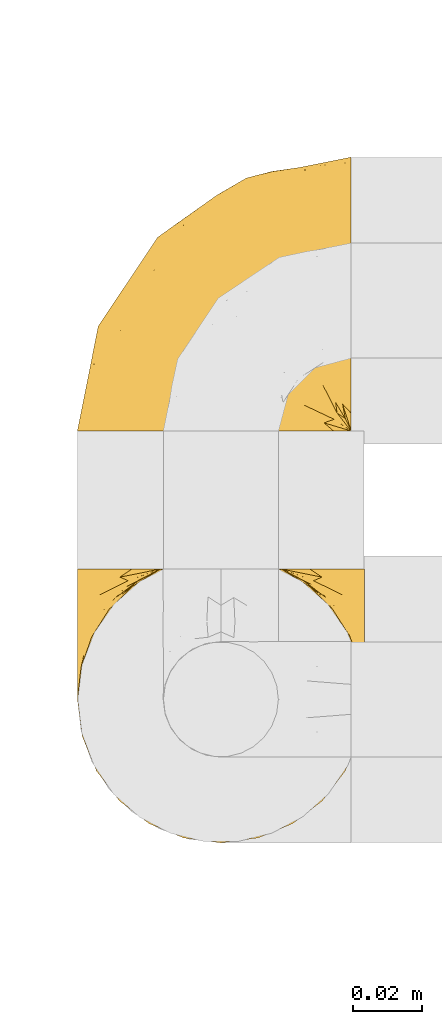
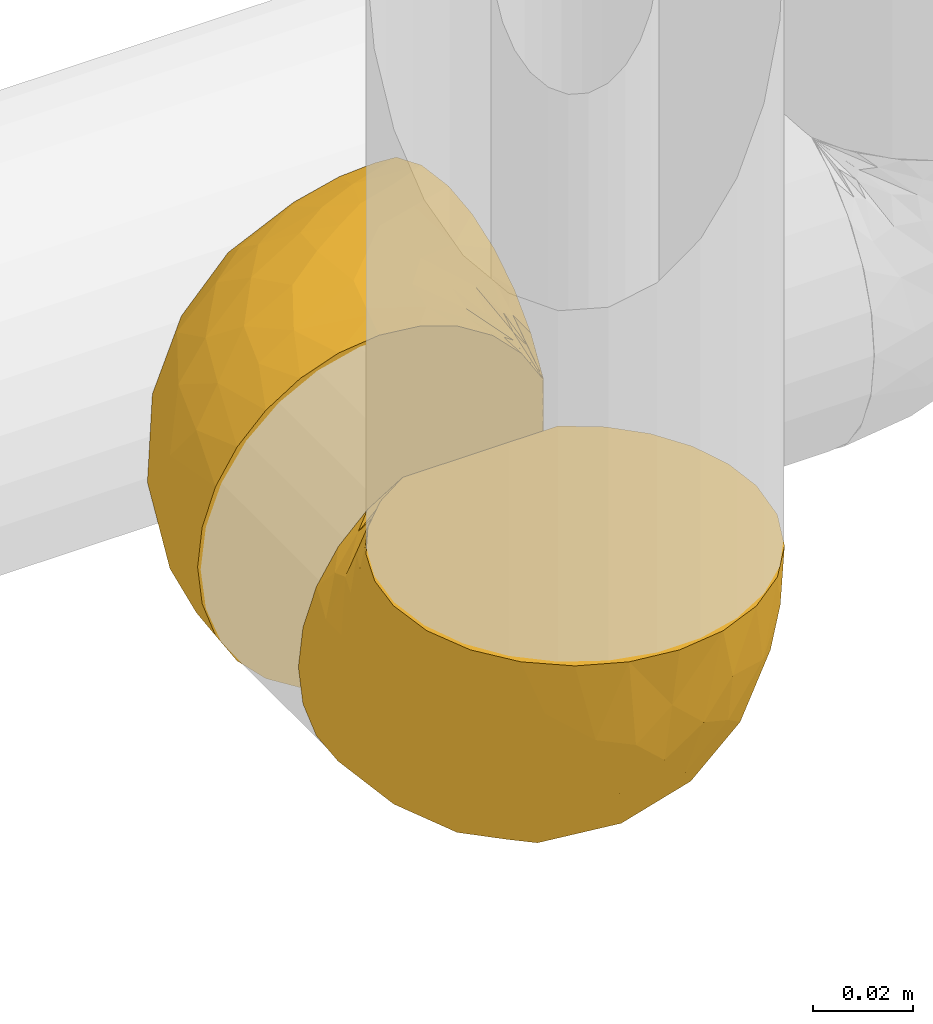
# One storey, part 445 of 827: 2 coverings.
"""IFC2X3 building model written with IfcOpenShell, lengths in millimetres."""

from ifc_helpers import new_model, entity, si_unit, converted_unit, derived_unit, direction, frame, origin, place, context, subcontext, project, spatial, faceted_brep, element, save


model = new_model("IFC2X3")

# Units and contexts
model_context = context("Model", 3, precision=0.01, world=origin(), true_north=direction((6.12303176911189e-17, 1.0)))
body_context = subcontext(model_context, "Body", "Model", "MODEL_VIEW")
ifc_project = project(units=[si_unit("LENGTHUNIT", "METRE", prefix="MILLI"), si_unit("AREAUNIT", "SQUARE_METRE"), si_unit("VOLUMEUNIT", "CUBIC_METRE"), converted_unit("PLANEANGLEUNIT", "DEGREE", entity("IfcRatioMeasure", 0.0174532925199433), si_unit("PLANEANGLEUNIT", "RADIAN"), dimensions=[0, 0, 0, 0, 0, 0, 0]), si_unit("MASSUNIT", "GRAM", prefix="KILO"), derived_unit("MASSDENSITYUNIT", [(si_unit("MASSUNIT", "GRAM", prefix="KILO"), 1), (si_unit("LENGTHUNIT", "METRE"), -3)]), derived_unit("MOMENTOFINERTIAUNIT", [(si_unit("LENGTHUNIT", "METRE"), 4)]), si_unit("TIMEUNIT", "SECOND"), si_unit("FREQUENCYUNIT", "HERTZ"), si_unit("THERMODYNAMICTEMPERATUREUNIT", "DEGREE_CELSIUS"), derived_unit("THERMALTRANSMITTANCEUNIT", [(si_unit("MASSUNIT", "GRAM", prefix="KILO"), 1), (si_unit("THERMODYNAMICTEMPERATUREUNIT", "KELVIN"), -1), (si_unit("TIMEUNIT", "SECOND"), -3)]), derived_unit("VOLUMETRICFLOWRATEUNIT", [(si_unit("LENGTHUNIT", "METRE"), 3), (si_unit("TIMEUNIT", "SECOND"), -1)]), derived_unit("MASSFLOWRATEUNIT", [(si_unit("MASSUNIT", "GRAM", prefix="KILO"), 1), (si_unit("TIMEUNIT", "SECOND"), -1)]), derived_unit("ROTATIONALFREQUENCYUNIT", [(si_unit("TIMEUNIT", "SECOND"), -1)]), si_unit("ELECTRICCURRENTUNIT", "AMPERE"), si_unit("ELECTRICVOLTAGEUNIT", "VOLT"), si_unit("POWERUNIT", "WATT"), si_unit("FORCEUNIT", "NEWTON", prefix="KILO"), si_unit("ILLUMINANCEUNIT", "LUX"), si_unit("LUMINOUSFLUXUNIT", "LUMEN"), si_unit("LUMINOUSINTENSITYUNIT", "CANDELA"), derived_unit("USERDEFINED", [(si_unit("MASSUNIT", "GRAM", prefix="KILO"), -1), (si_unit("LENGTHUNIT", "METRE"), -2), (si_unit("TIMEUNIT", "SECOND"), 3), (si_unit("LUMINOUSFLUXUNIT", "LUMEN"), 1)]), derived_unit("LINEARVELOCITYUNIT", [(si_unit("LENGTHUNIT", "METRE"), 1), (si_unit("TIMEUNIT", "SECOND"), -1)]), si_unit("PRESSUREUNIT", "PASCAL"), derived_unit("USERDEFINED", [(si_unit("LENGTHUNIT", "METRE"), -2), (si_unit("MASSUNIT", "GRAM", prefix="KILO"), 1), (si_unit("TIMEUNIT", "SECOND"), -2)]), derived_unit("LINEARFORCEUNIT", [(si_unit("MASSUNIT", "GRAM", prefix="KILO"), 1), (si_unit("LENGTHUNIT", "METRE"), 1), (si_unit("TIMEUNIT", "SECOND"), -2), (si_unit("LENGTHUNIT", "METRE"), -1)]), derived_unit("PLANARFORCEUNIT", [(si_unit("MASSUNIT", "GRAM", prefix="KILO"), 1), (si_unit("LENGTHUNIT", "METRE"), 1), (si_unit("TIMEUNIT", "SECOND"), -2), (si_unit("LENGTHUNIT", "METRE"), -2)])], contexts=[model_context])

# Site, building, storey
site_placement = place(None, origin())
site = spatial("IfcSite", under=ifc_project, at=site_placement, CompositionType="ELEMENT")
building_placement = place(site_placement, origin())
building = spatial("IfcBuilding", under=site, at=building_placement, CompositionType="ELEMENT")
storey_placement = place(building_placement, frame((0.0, 0.0, 28200.0)))
storey = spatial("IfcBuildingStorey", under=building, at=storey_placement, Name="08", CompositionType="ELEMENT", Elevation=28200.0)

# Coverings
covering_1_placement = place(storey_placement, frame((58830.44, 15400.76, 1657.08)))
element("IfcCovering", 1, at=covering_1_placement, inside=storey, Name=":ADSK_", ObjectType=":ADSK_", PredefinedType="INSULATION", context=body_context, shape_type="Brep", body=[
    faceted_brep([(81.15, 81.45, 25.28), (76.16, 81.45, 17.35), (69.53, 81.45, 10.72), (61.6, 81.45, 5.74), (52.75, 81.45, 2.64), (43.45, 81.45, 1.6), (34.13, 81.45, 2.65), (25.28, 81.45, 5.74), (17.35, 81.45, 10.73), (10.72, 81.45, 17.36), (5.74, 81.45, 25.29), (2.64, 81.45, 34.14), (1.6, 81.45, 43.45), (2.66, 81.45, 52.82), (5.79, 81.45, 61.71), (10.83, 81.45, 69.67), (17.53, 81.45, 76.31), (25.53, 81.45, 81.27), (26.45, 81.45, 81.27), (27.37, 81.45, 81.27), (28.17, 81.45, 81.27), (29.49, 81.45, 81.27), (30.81, 81.45, 81.27), (32.13, 81.45, 81.27), (33.45, 81.45, 81.27), (34.78, 81.45, 81.27), (36.1, 81.45, 81.27), (37.42, 81.45, 81.27), (38.74, 81.45, 81.27), (40.06, 81.45, 81.27), (41.38, 81.45, 81.27), (42.7, 81.45, 81.27), (44.02, 81.45, 81.27), (45.34, 81.45, 81.27), (46.66, 81.45, 81.27), (47.58, 81.45, 81.27), (48.5, 81.45, 81.27), (49.41, 81.45, 81.27), (50.33, 81.45, 81.27), (51.25, 81.45, 81.27), (52.17, 81.45, 81.27), (53.09, 81.45, 81.27), (54.01, 81.45, 81.27), (54.93, 81.45, 81.27), (55.85, 81.45, 81.27), (56.76, 81.45, 81.27), (57.68, 81.45, 81.27), (58.6, 81.45, 81.27), (59.52, 81.45, 81.27), (60.44, 81.45, 81.27), (61.36, 81.45, 81.27), (69.37, 81.45, 76.3), (76.07, 81.45, 69.66), (81.11, 81.45, 61.69), (84.24, 81.45, 52.8), (85.3, 81.45, 43.45), (84.24, 81.45, 34.13), (17.52, 76.3, 81.45), (10.83, 69.67, 81.45), (5.79, 61.7, 81.45), (2.66, 52.81, 81.45), (1.6, 43.45, 81.45), (3.02, 32.61, 81.45), (7.2, 22.52, 81.45), (13.85, 13.85, 81.45), (22.52, 7.2, 81.45), (32.61, 3.02, 81.45), (43.45, 1.6, 81.45), (54.28, 3.02, 81.45), (64.37, 7.2, 81.45), (73.04, 13.85, 81.45), (79.69, 22.52, 81.45), (83.87, 32.61, 81.45), (85.3, 43.45, 81.45), (84.23, 52.81, 81.45), (81.1, 61.7, 81.45), (76.06, 69.67, 81.45), (69.37, 76.3, 81.45), (61.36, 81.27, 81.45), (60.44, 81.27, 81.45), (59.12, 81.27, 81.45), (58.0, 81.27, 81.45), (56.88, 81.27, 81.45), (55.76, 81.27, 81.45), (54.64, 81.27, 81.45), (53.52, 81.27, 81.45), (52.4, 81.27, 81.45), (51.28, 81.27, 81.45), (50.16, 81.27, 81.45), (49.04, 81.27, 81.45), (47.92, 81.27, 81.45), (46.8, 81.27, 81.45), (45.68, 81.27, 81.45), (44.56, 81.27, 81.45), (43.45, 81.27, 81.45), (42.12, 81.27, 81.45), (40.8, 81.27, 81.45), (39.48, 81.27, 81.45), (38.16, 81.27, 81.45), (36.84, 81.27, 81.45), (35.52, 81.27, 81.45), (34.2, 81.27, 81.45), (32.88, 81.27, 81.45), (31.96, 81.27, 81.45), (31.05, 81.27, 81.45), (30.13, 81.27, 81.45), (29.21, 81.27, 81.45), (28.29, 81.27, 81.45), (27.37, 81.27, 81.45), (26.45, 81.27, 81.45), (25.53, 81.27, 81.45), (54.08, 81.31, 81.33), (55.16, 81.33, 81.32), (36.18, 81.31, 81.33), (35.13, 81.32, 81.32), (44.01, 81.31, 81.33), (45.08, 81.32, 81.32), (61.36, 81.32, 81.32), (59.98, 81.32, 81.32), (46.18, 81.32, 81.32), (26.74, 81.32, 81.32), (47.36, 81.32, 81.32), (29.67, 81.32, 81.32), (28.72, 81.3, 81.34), (39.77, 81.32, 81.32), (52.96, 81.33, 81.31), (51.84, 81.31, 81.33), (40.8, 81.33, 81.31), (41.87, 81.32, 81.32), (42.94, 81.32, 81.33), (27.77, 81.32, 81.32), (48.4, 81.31, 81.33), (37.21, 81.32, 81.32), (33.54, 81.31, 81.33), (32.49, 81.32, 81.32), (30.69, 81.32, 81.32), (50.69, 81.32, 81.32), (49.6, 81.33, 81.31), (56.32, 81.32, 81.32), (57.44, 81.31, 81.33), (58.88, 81.33, 81.31), (25.53, 81.32, 81.32), (61.36, 81.36, 81.3), (61.36, 81.4, 81.29), (25.53, 81.4, 81.29), (25.53, 81.36, 81.3), (61.36, 81.29, 81.4), (61.36, 81.3, 81.36), (25.53, 81.3, 81.36), (25.53, 81.29, 81.4), (31.59, 81.35, 81.3), (38.71, 81.31, 81.33), (3.97, 58.5, 74.06), (1.6, 71.95, 45.99), (3.97, 74.57, 58.35), (8.09, 73.93, 67.76), (8.09, 78.18, 66.18), (16.43, 78.04, 76.46), (15.73, 76.23, 77.33), (1.6, 45.99, 71.95), (10.79, 74.01, 72.25), (13.99, 73.57, 78.91), (8.08, 66.66, 76.42), (14.0, 79.09, 73.52), (12.83, 73.14, 76.9), (3.18, 60.34, 65.25), (1.6, 48.54, 62.45), (1.6, 45.36, 74.31), (3.28, 67.22, 59.38), (1.6, 62.45, 48.54), (6.28, 68.67, 67.72), (1.6, 55.49, 55.49), (19.06, 77.84, 79.73), (8.08, 68.16, 73.23), (1.6, 74.31, 45.36), (32.11, 38.78, 15.81), (29.62, 62.1, 6.4), (43.45, 50.89, 7.67), (2.45, 36.91, 68.46), (2.5, 40.37, 59.33), (9.73, 27.86, 48.7), (17.97, 15.77, 53.94), (10.24, 20.13, 65.02), (4.78, 31.54, 60.77), (4.78, 28.25, 72.07), (8.01, 57.26, 26.25), (8.01, 69.99, 22.29), (13.85, 64.58, 16.0), (2.42, 50.64, 46.93), (21.17, 51.97, 14.19), (35.73, 5.72, 58.46), (27.43, 7.42, 61.51), (43.45, 66.14, 4.64), (17.97, 11.35, 68.93), (35.71, 21.64, 29.62), (29.47, 28.57, 24.85), (3.41, 55.38, 38.55), (3.94, 68.51, 31.27), (21.17, 67.48, 9.35), (7.92, 40.78, 37.15), (4.25, 41.53, 47.07), (11.75, 46.11, 26.49), (18.31, 40.32, 23.01), (24.94, 38.36, 19.4), (28.78, 11.84, 48.06), (35.82, 12.56, 42.46), (43.45, 7.67, 50.89), (28.38, 19.39, 35.78), (43.45, 24.98, 24.98), (43.45, 37.94, 16.33), (43.45, 4.64, 66.14), (21.21, 28.09, 30.96), (16.48, 23.73, 41.83), (13.85, 34.03, 33.28), (43.45, 16.33, 37.94), (82.11, 29.29, 67.39), (51.41, 5.77, 58.47), (57.45, 21.44, 32.5), (54.78, 38.8, 15.79), (73.03, 64.58, 15.99), (65.7, 67.49, 9.34), (76.65, 22.9, 56.91), (68.92, 12.54, 63.5), (68.01, 20.04, 44.08), (78.88, 57.26, 26.24), (78.88, 69.99, 22.27), (82.94, 68.51, 31.26), (64.44, 34.54, 23.95), (84.49, 38.81, 63.79), (85.3, 48.54, 62.45), (85.3, 45.99, 71.95), (85.3, 74.31, 45.36), (57.84, 5.36, 67.83), (76.65, 18.96, 70.28), (51.19, 12.79, 42.11), (57.26, 62.11, 6.39), (78.14, 33.14, 43.54), (82.35, 33.44, 58.03), (65.7, 51.98, 14.18), (84.61, 43.42, 56.34), (84.36, 48.62, 48.09), (85.3, 62.45, 48.54), (85.3, 55.49, 55.49), (73.03, 49.68, 21.78), (83.48, 55.37, 38.54), (85.3, 71.95, 45.99), (84.54, 36.37, 72.79), (73.03, 34.04, 33.26), (79.54, 44.1, 35.53), (59.46, 9.99, 53.66), (73.5, 26.41, 43.03), (82.57, 39.19, 49.68), (82.92, 58.5, 74.06), (83.62, 67.22, 59.37), (82.92, 74.57, 58.34), (78.81, 73.92, 67.75), (72.9, 73.57, 78.91), (74.06, 73.14, 76.9), (78.81, 66.19, 78.08), (78.81, 68.16, 73.23), (67.83, 77.84, 79.73), (71.15, 76.23, 77.34), (72.91, 79.08, 73.51), (70.47, 78.04, 76.45), (78.81, 77.18, 66.41), (80.62, 68.66, 67.7), (76.11, 74.0, 72.24), (83.71, 60.34, 65.25)], [[[0, 1, 2, 3, 4, 5, 6, 7, 8, 9, 10, 11, 12, 13, 14, 15, 16, 17, 18, 19, 20, 21, 22, 23, 24, 25, 26, 27, 28, 29, 30, 31, 32, 33, 34, 35, 36, 37, 38, 39, 40, 41, 42, 43, 44, 45, 46, 47, 48, 49, 50, 51, 52, 53, 54, 55, 56]], [[57, 58, 59, 60, 61, 62, 63, 64, 65, 66, 67, 68, 69, 70, 71, 72, 73, 74, 75, 76, 77, 78, 79, 80, 81, 82, 83, 84, 85, 86, 87, 88, 89, 90, 91, 92, 93, 94, 95, 96, 97, 98, 99, 100, 101, 102, 103, 104, 105, 106, 107, 108, 109, 110]], [[111, 84, 112]], [[113, 26, 114]], [[114, 101, 100]], [[115, 93, 116]], [[79, 117, 118]], [[33, 116, 119]], [[117, 49, 118]], [[19, 18, 120]], [[119, 121, 34]], [[122, 21, 123]], [[97, 96, 124]], [[86, 125, 126]], [[116, 92, 119]], [[127, 96, 128]], [[32, 129, 115]], [[19, 120, 130]], [[121, 90, 131]], [[94, 115, 129]], [[115, 116, 32]], [[118, 49, 48]], [[113, 99, 132]], [[133, 114, 25]], [[24, 134, 133]], [[135, 22, 122]], [[136, 137, 88]], [[84, 83, 112]], [[138, 82, 139]], [[130, 20, 19]], [[118, 48, 140]], [[81, 140, 139]], [[123, 21, 20]], [[141, 120, 18]], [[139, 82, 81]], [[130, 107, 123]], [[49, 117, 142, 143, 50]], [[18, 17, 144, 145, 141]], [[79, 78, 146, 147, 117]], [[109, 141, 148, 149, 110]], [[102, 133, 134]], [[105, 135, 122]], [[118, 80, 79]], [[80, 118, 140]], [[120, 109, 108]], [[47, 46, 140, 48]], [[81, 80, 140]], [[44, 112, 138]], [[93, 115, 94]], [[46, 139, 140]], [[46, 45, 139]], [[139, 45, 138]], [[138, 112, 83]], [[85, 84, 111]], [[112, 43, 111]], [[83, 82, 138]], [[106, 122, 123]], [[105, 122, 106]], [[21, 122, 22]], [[124, 29, 28]], [[33, 32, 116]], [[128, 129, 31]], [[32, 31, 129]], [[34, 33, 119]], [[116, 93, 92]], [[129, 95, 94]], [[95, 129, 128]], [[41, 40, 125, 42]], [[119, 91, 121]], [[36, 35, 131, 37]], [[137, 131, 89]], [[121, 131, 35]], [[90, 121, 91]], [[119, 92, 91]], [[136, 126, 39]], [[125, 86, 85]], [[42, 125, 111]], [[85, 111, 125]], [[150, 23, 22]], [[130, 108, 107]], [[130, 123, 20]], [[107, 106, 123]], [[137, 37, 131]], [[136, 38, 137]], [[89, 88, 137]], [[131, 90, 89]], [[124, 151, 97]], [[40, 39, 126]], [[87, 126, 136]], [[86, 126, 87]], [[136, 88, 87]], [[40, 126, 125]], [[39, 38, 136]], [[95, 128, 96]], [[30, 128, 31]], [[29, 124, 127]], [[127, 128, 30]], [[151, 124, 28]], [[127, 30, 29]], [[127, 124, 96]], [[151, 98, 97]], [[45, 44, 138]], [[26, 113, 132]], [[113, 100, 99]], [[132, 151, 27]], [[27, 26, 132]], [[26, 25, 114]], [[100, 113, 114]], [[101, 133, 102]], [[133, 101, 114]], [[28, 27, 151]], [[132, 99, 98]], [[23, 134, 24]], [[25, 24, 133]], [[134, 23, 150]], [[135, 104, 150]], [[150, 104, 103]], [[103, 102, 134]], [[130, 120, 108]], [[109, 120, 141]], [[42, 111, 43]], [[112, 44, 43]], [[104, 135, 105]], [[134, 150, 103]], [[135, 150, 22]], [[35, 34, 121]], [[137, 38, 37]], [[98, 151, 132]], [[59, 152, 60]], [[13, 153, 154]], [[155, 156, 154]], [[157, 158, 141]], [[159, 60, 152]], [[160, 157, 155]], [[161, 162, 58]], [[58, 162, 59]], [[144, 16, 163]], [[58, 57, 161]], [[162, 161, 164]], [[157, 163, 155]], [[163, 16, 15]], [[57, 149, 161]], [[152, 165, 166]], [[157, 144, 163]], [[60, 159, 167, 61]], [[156, 14, 154]], [[163, 156, 155]], [[155, 154, 168]], [[168, 154, 169]], [[155, 170, 160]], [[57, 110, 149]], [[144, 17, 16]], [[156, 15, 14]], [[171, 165, 168]], [[158, 164, 172]], [[14, 13, 154]], [[157, 141, 145, 144]], [[173, 164, 158]], [[173, 160, 170]], [[171, 166, 165]], [[168, 165, 170]], [[168, 169, 171]], [[152, 173, 165]], [[170, 155, 168]], [[165, 173, 170]], [[160, 173, 158]], [[172, 149, 148]], [[148, 141, 158]], [[158, 157, 160]], [[152, 166, 159]], [[173, 152, 162]], [[59, 162, 152]], [[13, 12, 174, 153]], [[153, 169, 154]], [[15, 156, 163]], [[162, 164, 173]], [[172, 164, 161]], [[149, 172, 161]], [[158, 172, 148]], [[175, 176, 177]], [[178, 166, 179]], [[180, 181, 182]], [[183, 184, 178]], [[185, 186, 187]], [[171, 188, 179]], [[174, 12, 11]], [[189, 176, 175]], [[190, 66, 191]], [[176, 6, 192]], [[193, 65, 64]], [[63, 184, 182]], [[63, 182, 64]], [[65, 193, 191]], [[184, 63, 62]], [[175, 194, 195]], [[196, 169, 197]], [[174, 11, 197]], [[8, 7, 198]], [[187, 9, 8]], [[197, 169, 153, 174]], [[197, 11, 10]], [[186, 197, 10]], [[199, 180, 200]], [[197, 185, 196]], [[201, 189, 202]], [[201, 187, 189]], [[195, 203, 175]], [[191, 204, 190]], [[176, 7, 6]], [[177, 176, 192]], [[189, 198, 176]], [[65, 191, 66]], [[198, 187, 8]], [[205, 206, 190]], [[9, 186, 10]], [[181, 207, 204]], [[208, 175, 177, 209]], [[66, 190, 210]], [[211, 212, 213]], [[190, 204, 205]], [[180, 182, 183]], [[193, 182, 181]], [[62, 61, 167]], [[196, 185, 199]], [[196, 200, 188]], [[6, 5, 192]], [[176, 198, 7]], [[187, 198, 189]], [[187, 186, 9]], [[197, 186, 185]], [[200, 180, 183]], [[180, 213, 212]], [[179, 183, 178]], [[185, 201, 199]], [[210, 190, 206]], [[210, 67, 66]], [[205, 204, 207]], [[194, 205, 207]], [[194, 214, 205]], [[195, 194, 207]], [[208, 194, 175]], [[207, 211, 195]], [[202, 203, 211]], [[212, 207, 181]], [[202, 211, 213]], [[201, 202, 213]], [[189, 175, 203]], [[199, 201, 213]], [[187, 201, 185]], [[180, 199, 213]], [[196, 199, 200]], [[211, 203, 195]], [[189, 203, 202]], [[207, 212, 211]], [[180, 212, 181]], [[214, 194, 208]], [[214, 206, 205]], [[196, 188, 169]], [[181, 204, 191]], [[182, 193, 64]], [[191, 193, 181]], [[178, 62, 167]], [[182, 184, 183]], [[62, 178, 184]], [[178, 167, 159, 166]], [[171, 179, 166]], [[200, 183, 179]], [[179, 188, 200]], [[169, 188, 171]], [[71, 215, 72]], [[206, 216, 210]], [[217, 208, 218]], [[216, 68, 210]], [[219, 220, 2]], [[221, 222, 223]], [[224, 225, 226]], [[227, 223, 217]], [[228, 229, 230]], [[56, 231, 226]], [[232, 222, 69]], [[56, 55, 231]], [[70, 233, 71]], [[71, 233, 215]], [[0, 56, 226]], [[208, 217, 234]], [[218, 177, 235]], [[221, 236, 237]], [[238, 220, 219]], [[1, 219, 2]], [[68, 216, 232]], [[235, 3, 220]], [[235, 192, 4]], [[1, 0, 225]], [[228, 239, 229]], [[240, 241, 242]], [[243, 238, 219]], [[224, 226, 244]], [[226, 241, 244]], [[3, 235, 4]], [[69, 222, 70]], [[225, 219, 1]], [[218, 235, 238]], [[243, 219, 224]], [[218, 227, 217]], [[3, 2, 220]], [[218, 208, 209, 177]], [[226, 231, 245, 241]], [[215, 228, 246]], [[247, 248, 236]], [[248, 224, 244]], [[223, 222, 249]], [[233, 222, 221]], [[242, 239, 240]], [[248, 247, 243]], [[217, 223, 249]], [[250, 247, 236]], [[216, 234, 249]], [[218, 238, 227]], [[192, 235, 177]], [[192, 5, 4]], [[72, 246, 73]], [[235, 220, 238]], [[226, 225, 0]], [[219, 225, 224]], [[240, 248, 244]], [[239, 242, 229]], [[236, 248, 251]], [[68, 67, 210]], [[234, 216, 206]], [[216, 249, 232]], [[234, 206, 214, 208]], [[249, 234, 217]], [[222, 232, 249]], [[69, 68, 232]], [[246, 228, 230]], [[237, 228, 215]], [[243, 227, 238]], [[223, 227, 247]], [[73, 246, 230]], [[215, 246, 72]], [[248, 243, 224]], [[227, 243, 247]], [[237, 236, 251]], [[250, 221, 223]], [[222, 233, 70]], [[215, 233, 221]], [[221, 237, 215]], [[239, 237, 251]], [[237, 239, 228]], [[239, 251, 240]], [[248, 240, 251]], [[241, 240, 244]], [[221, 250, 236]], [[223, 247, 250]], [[74, 230, 252]], [[253, 254, 255]], [[146, 77, 256]], [[257, 258, 259]], [[260, 256, 257]], [[260, 261, 147]], [[75, 74, 252]], [[51, 143, 262]], [[263, 143, 142, 117]], [[256, 77, 76]], [[252, 258, 75]], [[253, 241, 254]], [[254, 245, 54]], [[258, 256, 76]], [[53, 52, 264]], [[255, 265, 253]], [[254, 264, 255]], [[255, 264, 262]], [[75, 258, 76]], [[265, 255, 266]], [[255, 262, 263]], [[51, 50, 143]], [[54, 245, 231, 55]], [[51, 262, 52]], [[253, 267, 242]], [[254, 54, 53]], [[266, 259, 265]], [[146, 78, 77]], [[263, 117, 261]], [[146, 256, 260]], [[257, 259, 261]], [[267, 253, 265]], [[229, 267, 252]], [[242, 267, 229]], [[242, 241, 253]], [[252, 267, 259]], [[255, 263, 266]], [[259, 267, 265]], [[261, 117, 147]], [[263, 261, 266]], [[259, 266, 261]], [[230, 74, 73]], [[230, 229, 252]], [[259, 258, 252]], [[254, 241, 245]], [[53, 264, 254]], [[52, 262, 264]], [[143, 263, 262]], [[258, 257, 256]], [[261, 260, 257]], [[146, 260, 147]]]),
])
covering_2_placement = place(storey_placement, frame((58830.44, 15520.87, 1657.08)))
element("IfcCovering", 2, at=covering_2_placement, inside=storey, Name=":ADSK_", ObjectType=":ADSK_", PredefinedType="INSULATION", context=body_context, shape_type="Brep", body=[
    faceted_brep([(25.28, 1.6, 81.15), (17.35, 1.6, 76.16), (10.72, 1.6, 69.53), (5.74, 1.6, 61.6), (2.64, 1.6, 52.75), (1.6, 1.6, 43.45), (2.65, 1.6, 34.13), (5.74, 1.6, 25.28), (10.73, 1.6, 17.35), (17.36, 1.6, 10.72), (25.29, 1.6, 5.74), (34.14, 1.6, 2.64), (43.45, 1.6, 1.6), (52.82, 1.6, 2.66), (61.71, 1.6, 5.79), (69.67, 1.6, 10.83), (76.31, 1.6, 17.53), (81.27, 1.6, 25.53), (81.27, 1.6, 26.45), (81.27, 1.6, 27.37), (81.27, 1.6, 28.17), (81.27, 1.6, 29.49), (81.27, 1.6, 30.81), (81.27, 1.6, 32.13), (81.27, 1.6, 33.45), (81.27, 1.6, 34.78), (81.27, 1.6, 36.1), (81.27, 1.6, 37.42), (81.27, 1.6, 38.74), (81.27, 1.6, 40.06), (81.27, 1.6, 41.38), (81.27, 1.6, 42.7), (81.27, 1.6, 44.02), (81.27, 1.6, 45.34), (81.27, 1.6, 46.66), (81.27, 1.6, 47.58), (81.27, 1.6, 48.5), (81.27, 1.6, 49.41), (81.27, 1.6, 50.33), (81.27, 1.6, 51.25), (81.27, 1.6, 52.17), (81.27, 1.6, 53.09), (81.27, 1.6, 54.01), (81.27, 1.6, 54.93), (81.27, 1.6, 55.85), (81.27, 1.6, 56.76), (81.27, 1.6, 57.68), (81.27, 1.6, 58.6), (81.27, 1.6, 59.52), (81.27, 1.6, 60.44), (81.27, 1.6, 61.36), (76.3, 1.6, 69.37), (69.66, 1.6, 76.07), (61.69, 1.6, 81.11), (52.8, 1.6, 84.24), (43.45, 1.6, 85.3), (34.13, 1.6, 84.24), (81.45, 6.74, 17.52), (81.45, 13.37, 10.83), (81.45, 21.34, 5.79), (81.45, 30.23, 2.66), (81.45, 39.6, 1.6), (81.45, 50.43, 3.02), (81.45, 60.52, 7.2), (81.45, 69.19, 13.85), (81.45, 75.84, 22.52), (81.45, 80.02, 32.61), (81.45, 81.45, 43.45), (81.45, 80.02, 54.28), (81.45, 75.84, 64.37), (81.45, 69.19, 73.04), (81.45, 60.52, 79.69), (81.45, 50.43, 83.87), (81.45, 39.6, 85.3), (81.45, 30.23, 84.23), (81.45, 21.34, 81.1), (81.45, 13.37, 76.06), (81.45, 6.74, 69.37), (81.45, 1.77, 61.36), (81.45, 1.77, 60.44), (81.45, 1.77, 59.12), (81.45, 1.77, 58.0), (81.45, 1.77, 56.88), (81.45, 1.77, 55.76), (81.45, 1.77, 54.64), (81.45, 1.77, 53.52), (81.45, 1.77, 52.4), (81.45, 1.77, 51.28), (81.45, 1.77, 50.16), (81.45, 1.77, 49.04), (81.45, 1.77, 47.92), (81.45, 1.77, 46.8), (81.45, 1.77, 45.68), (81.45, 1.77, 44.56), (81.45, 1.77, 43.45), (81.45, 1.77, 42.12), (81.45, 1.77, 40.8), (81.45, 1.77, 39.48), (81.45, 1.77, 38.16), (81.45, 1.77, 36.84), (81.45, 1.77, 35.52), (81.45, 1.77, 34.2), (81.45, 1.77, 32.88), (81.45, 1.77, 31.96), (81.45, 1.77, 31.05), (81.45, 1.77, 30.13), (81.45, 1.77, 29.21), (81.45, 1.77, 28.29), (81.45, 1.77, 27.37), (81.45, 1.77, 26.45), (81.45, 1.77, 25.53), (81.33, 1.73, 54.08), (81.32, 1.72, 55.16), (81.33, 1.73, 36.18), (81.32, 1.72, 35.13), (81.33, 1.73, 44.01), (81.32, 1.73, 45.08), (81.32, 1.72, 61.36), (81.32, 1.72, 59.98), (81.32, 1.72, 46.18), (81.32, 1.72, 26.74), (81.32, 1.72, 47.36), (81.32, 1.73, 29.67), (81.34, 1.74, 28.72), (81.32, 1.72, 39.77), (81.31, 1.71, 52.96), (81.33, 1.73, 51.84), (81.31, 1.71, 40.8), (81.32, 1.72, 41.87), (81.33, 1.73, 42.94), (81.32, 1.72, 27.77), (81.33, 1.73, 48.4), (81.32, 1.72, 37.21), (81.33, 1.73, 33.54), (81.32, 1.72, 32.49), (81.32, 1.72, 30.69), (81.32, 1.72, 50.69), (81.31, 1.71, 49.6), (81.32, 1.72, 56.32), (81.33, 1.73, 57.44), (81.31, 1.71, 58.88), (81.32, 1.72, 25.53), (81.3, 1.68, 61.36), (81.29, 1.64, 61.36), (81.29, 1.64, 25.53), (81.3, 1.68, 25.53), (81.4, 1.75, 61.36), (81.36, 1.74, 61.36), (81.36, 1.74, 25.53), (81.4, 1.75, 25.53), (81.3, 1.7, 31.59), (81.33, 1.73, 38.71), (74.06, 24.54, 3.97), (45.99, 11.1, 1.6), (58.35, 8.47, 3.97), (67.76, 9.11, 8.09), (66.18, 4.86, 8.09), (76.46, 5.0, 16.43), (77.33, 6.81, 15.73), (71.95, 37.05, 1.6), (72.25, 9.03, 10.79), (78.91, 9.47, 13.99), (76.42, 16.39, 8.08), (73.52, 3.95, 14.0), (76.9, 9.9, 12.83), (65.25, 22.7, 3.18), (62.45, 34.5, 1.6), (74.31, 37.68, 1.6), (59.38, 15.82, 3.28), (48.54, 20.6, 1.6), (67.72, 14.37, 6.28), (55.49, 27.55, 1.6), (79.73, 5.2, 19.06), (73.23, 14.88, 8.08), (45.36, 8.73, 1.6), (15.81, 44.27, 32.11), (6.4, 20.94, 29.62), (7.67, 32.15, 43.45), (68.46, 46.13, 2.45), (59.33, 42.67, 2.5), (48.7, 55.18, 9.73), (53.94, 67.27, 17.97), (65.02, 62.91, 10.24), (60.77, 51.5, 4.78), (72.07, 54.79, 4.78), (26.25, 25.78, 8.01), (22.29, 13.05, 8.01), (16.0, 18.46, 13.85), (46.93, 32.4, 2.42), (14.19, 31.07, 21.17), (58.46, 77.32, 35.73), (61.51, 75.62, 27.43), (4.64, 16.9, 43.45), (68.93, 71.69, 17.97), (29.62, 61.4, 35.71), (24.85, 54.47, 29.47), (38.55, 27.66, 3.41), (31.27, 14.53, 3.94), (9.35, 15.56, 21.17), (37.15, 42.26, 7.92), (47.07, 41.51, 4.25), (26.49, 36.93, 11.75), (23.01, 42.72, 18.31), (19.4, 44.68, 24.94), (48.06, 71.2, 28.78), (42.46, 70.48, 35.82), (50.89, 75.37, 43.45), (35.78, 63.65, 28.38), (24.98, 58.06, 43.45), (16.33, 45.11, 43.45), (66.14, 78.4, 43.45), (30.96, 54.95, 21.21), (41.83, 59.31, 16.48), (33.28, 49.01, 13.85), (37.94, 66.71, 43.45), (67.39, 53.75, 82.11), (58.47, 77.27, 51.41), (32.5, 61.6, 57.45), (15.79, 44.24, 54.78), (15.99, 18.46, 73.03), (9.34, 15.55, 65.7), (56.91, 60.14, 76.65), (63.5, 70.5, 68.92), (44.08, 63.0, 68.01), (26.24, 25.78, 78.88), (22.27, 13.05, 78.88), (31.26, 14.53, 82.94), (23.95, 48.5, 64.44), (63.79, 44.23, 84.49), (62.45, 34.5, 85.3), (71.95, 37.05, 85.3), (45.36, 8.73, 85.3), (67.83, 77.68, 57.84), (70.28, 64.08, 76.65), (42.11, 70.25, 51.19), (6.39, 20.93, 57.26), (43.54, 49.9, 78.14), (58.03, 49.6, 82.35), (14.18, 31.06, 65.7), (56.34, 39.62, 84.61), (48.09, 34.42, 84.36), (48.54, 20.6, 85.3), (55.49, 27.55, 85.3), (21.78, 33.36, 73.03), (38.54, 27.68, 83.48), (45.99, 11.1, 85.3), (72.79, 46.67, 84.54), (33.26, 49.0, 73.03), (35.53, 38.94, 79.54), (53.66, 73.05, 59.46), (43.03, 56.63, 73.5), (49.68, 43.85, 82.57), (74.06, 24.54, 82.92), (59.37, 15.82, 83.62), (58.34, 8.47, 82.92), (67.75, 9.12, 78.81), (78.91, 9.47, 72.9), (76.9, 9.91, 74.06), (78.08, 16.85, 78.81), (73.23, 14.88, 78.81), (79.73, 5.2, 67.83), (77.34, 6.81, 71.15), (73.51, 3.96, 72.91), (76.45, 5.0, 70.47), (66.41, 5.86, 78.81), (67.7, 14.38, 80.62), (72.24, 9.04, 76.11), (65.25, 22.7, 83.71)], [[[0, 1, 2, 3, 4, 5, 6, 7, 8, 9, 10, 11, 12, 13, 14, 15, 16, 17, 18, 19, 20, 21, 22, 23, 24, 25, 26, 27, 28, 29, 30, 31, 32, 33, 34, 35, 36, 37, 38, 39, 40, 41, 42, 43, 44, 45, 46, 47, 48, 49, 50, 51, 52, 53, 54, 55, 56]], [[57, 58, 59, 60, 61, 62, 63, 64, 65, 66, 67, 68, 69, 70, 71, 72, 73, 74, 75, 76, 77, 78, 79, 80, 81, 82, 83, 84, 85, 86, 87, 88, 89, 90, 91, 92, 93, 94, 95, 96, 97, 98, 99, 100, 101, 102, 103, 104, 105, 106, 107, 108, 109, 110]], [[111, 84, 112]], [[113, 26, 114]], [[114, 101, 100]], [[115, 93, 116]], [[79, 117, 118]], [[33, 116, 119]], [[117, 49, 118]], [[19, 18, 120]], [[119, 121, 34]], [[122, 21, 123]], [[97, 96, 124]], [[86, 125, 126]], [[116, 92, 119]], [[127, 96, 128]], [[32, 129, 115]], [[19, 120, 130]], [[121, 90, 131]], [[94, 115, 129]], [[115, 116, 32]], [[118, 49, 48]], [[113, 99, 132]], [[133, 114, 25]], [[24, 134, 133]], [[135, 22, 122]], [[136, 137, 88]], [[84, 83, 112]], [[138, 82, 139]], [[130, 20, 19]], [[118, 48, 140]], [[81, 140, 139]], [[123, 21, 20]], [[141, 120, 18]], [[139, 82, 81]], [[130, 107, 123]], [[49, 117, 142, 143, 50]], [[18, 17, 144, 145, 141]], [[79, 78, 146, 147, 117]], [[109, 141, 148, 149, 110]], [[102, 133, 134]], [[105, 135, 122]], [[118, 80, 79]], [[80, 118, 140]], [[120, 109, 108]], [[47, 46, 140, 48]], [[81, 80, 140]], [[44, 112, 138]], [[93, 115, 94]], [[46, 139, 140]], [[46, 45, 139]], [[139, 45, 138]], [[138, 112, 83]], [[85, 84, 111]], [[112, 43, 111]], [[83, 82, 138]], [[106, 122, 123]], [[105, 122, 106]], [[21, 122, 22]], [[124, 29, 28]], [[33, 32, 116]], [[128, 129, 31]], [[32, 31, 129]], [[34, 33, 119]], [[116, 93, 92]], [[129, 95, 94]], [[95, 129, 128]], [[41, 40, 125, 42]], [[119, 91, 121]], [[36, 35, 131, 37]], [[137, 131, 89]], [[121, 131, 35]], [[90, 121, 91]], [[119, 92, 91]], [[136, 126, 39]], [[125, 86, 85]], [[42, 125, 111]], [[85, 111, 125]], [[150, 23, 22]], [[130, 108, 107]], [[130, 123, 20]], [[107, 106, 123]], [[137, 37, 131]], [[136, 38, 137]], [[89, 88, 137]], [[131, 90, 89]], [[124, 151, 97]], [[40, 39, 126]], [[87, 126, 136]], [[86, 126, 87]], [[136, 88, 87]], [[40, 126, 125]], [[39, 38, 136]], [[95, 128, 96]], [[30, 128, 31]], [[29, 124, 127]], [[127, 128, 30]], [[151, 124, 28]], [[127, 30, 29]], [[127, 124, 96]], [[151, 98, 97]], [[45, 44, 138]], [[26, 113, 132]], [[113, 100, 99]], [[132, 151, 27]], [[27, 26, 132]], [[26, 25, 114]], [[100, 113, 114]], [[101, 133, 102]], [[133, 101, 114]], [[28, 27, 151]], [[132, 99, 98]], [[23, 134, 24]], [[25, 24, 133]], [[134, 23, 150]], [[135, 104, 150]], [[150, 104, 103]], [[103, 102, 134]], [[130, 120, 108]], [[109, 120, 141]], [[42, 111, 43]], [[112, 44, 43]], [[104, 135, 105]], [[134, 150, 103]], [[135, 150, 22]], [[35, 34, 121]], [[137, 38, 37]], [[98, 151, 132]], [[59, 152, 60]], [[13, 153, 154]], [[155, 156, 154]], [[157, 158, 141]], [[159, 60, 152]], [[160, 157, 155]], [[161, 162, 58]], [[58, 162, 59]], [[144, 16, 163]], [[58, 57, 161]], [[162, 161, 164]], [[157, 163, 155]], [[163, 16, 15]], [[57, 149, 161]], [[152, 165, 166]], [[157, 144, 163]], [[60, 159, 167, 61]], [[156, 14, 154]], [[163, 156, 155]], [[155, 154, 168]], [[168, 154, 169]], [[155, 170, 160]], [[57, 110, 149]], [[144, 17, 16]], [[156, 15, 14]], [[171, 165, 168]], [[158, 164, 172]], [[14, 13, 154]], [[157, 141, 145, 144]], [[173, 164, 158]], [[173, 160, 170]], [[171, 166, 165]], [[168, 165, 170]], [[168, 169, 171]], [[152, 173, 165]], [[170, 155, 168]], [[165, 173, 170]], [[160, 173, 158]], [[172, 149, 148]], [[148, 141, 158]], [[158, 157, 160]], [[152, 166, 159]], [[173, 152, 162]], [[59, 162, 152]], [[13, 12, 174, 153]], [[153, 169, 154]], [[15, 156, 163]], [[162, 164, 173]], [[172, 164, 161]], [[149, 172, 161]], [[158, 172, 148]], [[175, 176, 177]], [[178, 166, 179]], [[180, 181, 182]], [[183, 184, 178]], [[185, 186, 187]], [[171, 188, 179]], [[174, 12, 11]], [[189, 176, 175]], [[190, 66, 191]], [[176, 6, 192]], [[193, 65, 64]], [[63, 184, 182]], [[63, 182, 64]], [[65, 193, 191]], [[184, 63, 62]], [[175, 194, 195]], [[196, 169, 197]], [[174, 11, 197]], [[8, 7, 198]], [[187, 9, 8]], [[197, 169, 153, 174]], [[197, 11, 10]], [[186, 197, 10]], [[199, 180, 200]], [[197, 185, 196]], [[201, 189, 202]], [[201, 187, 189]], [[195, 203, 175]], [[191, 204, 190]], [[176, 7, 6]], [[177, 176, 192]], [[189, 198, 176]], [[65, 191, 66]], [[198, 187, 8]], [[205, 206, 190]], [[9, 186, 10]], [[181, 207, 204]], [[208, 175, 177, 209]], [[66, 190, 210]], [[211, 212, 213]], [[190, 204, 205]], [[180, 182, 183]], [[193, 182, 181]], [[62, 61, 167]], [[196, 185, 199]], [[196, 200, 188]], [[6, 5, 192]], [[176, 198, 7]], [[187, 198, 189]], [[187, 186, 9]], [[197, 186, 185]], [[200, 180, 183]], [[180, 213, 212]], [[179, 183, 178]], [[185, 201, 199]], [[210, 190, 206]], [[210, 67, 66]], [[205, 204, 207]], [[194, 205, 207]], [[194, 214, 205]], [[195, 194, 207]], [[208, 194, 175]], [[207, 211, 195]], [[202, 203, 211]], [[212, 207, 181]], [[202, 211, 213]], [[201, 202, 213]], [[189, 175, 203]], [[199, 201, 213]], [[187, 201, 185]], [[180, 199, 213]], [[196, 199, 200]], [[211, 203, 195]], [[189, 203, 202]], [[207, 212, 211]], [[180, 212, 181]], [[214, 194, 208]], [[214, 206, 205]], [[196, 188, 169]], [[181, 204, 191]], [[182, 193, 64]], [[191, 193, 181]], [[178, 62, 167]], [[182, 184, 183]], [[62, 178, 184]], [[178, 167, 159, 166]], [[171, 179, 166]], [[200, 183, 179]], [[179, 188, 200]], [[169, 188, 171]], [[71, 215, 72]], [[206, 216, 210]], [[217, 208, 218]], [[216, 68, 210]], [[219, 220, 2]], [[221, 222, 223]], [[224, 225, 226]], [[227, 223, 217]], [[228, 229, 230]], [[56, 231, 226]], [[232, 222, 69]], [[56, 55, 231]], [[70, 233, 71]], [[71, 233, 215]], [[0, 56, 226]], [[208, 217, 234]], [[218, 177, 235]], [[221, 236, 237]], [[238, 220, 219]], [[1, 219, 2]], [[68, 216, 232]], [[235, 3, 220]], [[235, 192, 4]], [[1, 0, 225]], [[228, 239, 229]], [[240, 241, 242]], [[243, 238, 219]], [[224, 226, 244]], [[226, 241, 244]], [[3, 235, 4]], [[69, 222, 70]], [[225, 219, 1]], [[218, 235, 238]], [[243, 219, 224]], [[218, 227, 217]], [[3, 2, 220]], [[218, 208, 209, 177]], [[226, 231, 245, 241]], [[215, 228, 246]], [[247, 248, 236]], [[248, 224, 244]], [[223, 222, 249]], [[233, 222, 221]], [[242, 239, 240]], [[248, 247, 243]], [[217, 223, 249]], [[250, 247, 236]], [[216, 234, 249]], [[218, 238, 227]], [[192, 235, 177]], [[192, 5, 4]], [[72, 246, 73]], [[235, 220, 238]], [[226, 225, 0]], [[219, 225, 224]], [[240, 248, 244]], [[239, 242, 229]], [[236, 248, 251]], [[68, 67, 210]], [[234, 216, 206]], [[216, 249, 232]], [[234, 206, 214, 208]], [[249, 234, 217]], [[222, 232, 249]], [[69, 68, 232]], [[246, 228, 230]], [[237, 228, 215]], [[243, 227, 238]], [[223, 227, 247]], [[73, 246, 230]], [[215, 246, 72]], [[248, 243, 224]], [[227, 243, 247]], [[237, 236, 251]], [[250, 221, 223]], [[222, 233, 70]], [[215, 233, 221]], [[221, 237, 215]], [[239, 237, 251]], [[237, 239, 228]], [[239, 251, 240]], [[248, 240, 251]], [[241, 240, 244]], [[221, 250, 236]], [[223, 247, 250]], [[74, 230, 252]], [[253, 254, 255]], [[146, 77, 256]], [[257, 258, 259]], [[260, 256, 257]], [[260, 261, 147]], [[75, 74, 252]], [[51, 143, 262]], [[263, 143, 142, 117]], [[256, 77, 76]], [[252, 258, 75]], [[253, 241, 254]], [[254, 245, 54]], [[258, 256, 76]], [[53, 52, 264]], [[255, 265, 253]], [[254, 264, 255]], [[255, 264, 262]], [[75, 258, 76]], [[265, 255, 266]], [[255, 262, 263]], [[51, 50, 143]], [[54, 245, 231, 55]], [[51, 262, 52]], [[253, 267, 242]], [[254, 54, 53]], [[266, 259, 265]], [[146, 78, 77]], [[263, 117, 261]], [[146, 256, 260]], [[257, 259, 261]], [[267, 253, 265]], [[229, 267, 252]], [[242, 267, 229]], [[242, 241, 253]], [[252, 267, 259]], [[255, 263, 266]], [[259, 267, 265]], [[261, 117, 147]], [[263, 261, 266]], [[259, 266, 261]], [[230, 74, 73]], [[230, 229, 252]], [[259, 258, 252]], [[254, 241, 245]], [[53, 264, 254]], [[52, 262, 264]], [[143, 263, 262]], [[258, 257, 256]], [[261, 260, 257]], [[146, 260, 147]]]),
])

save(model, "model.ifc")
